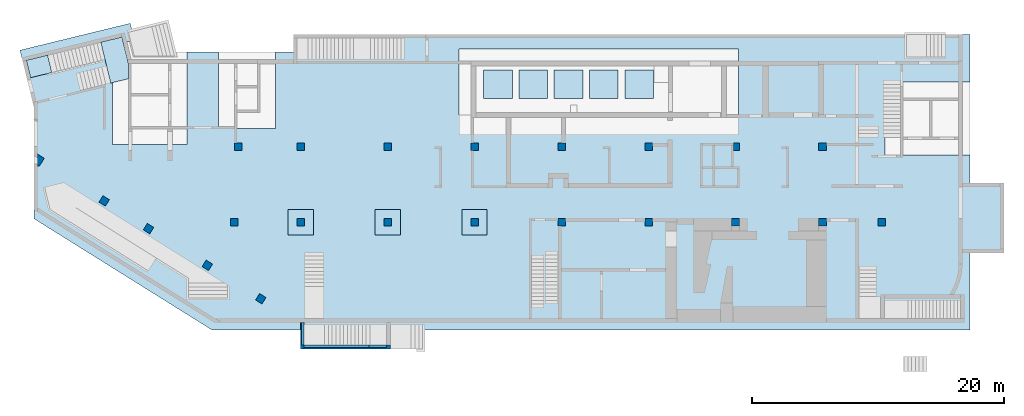
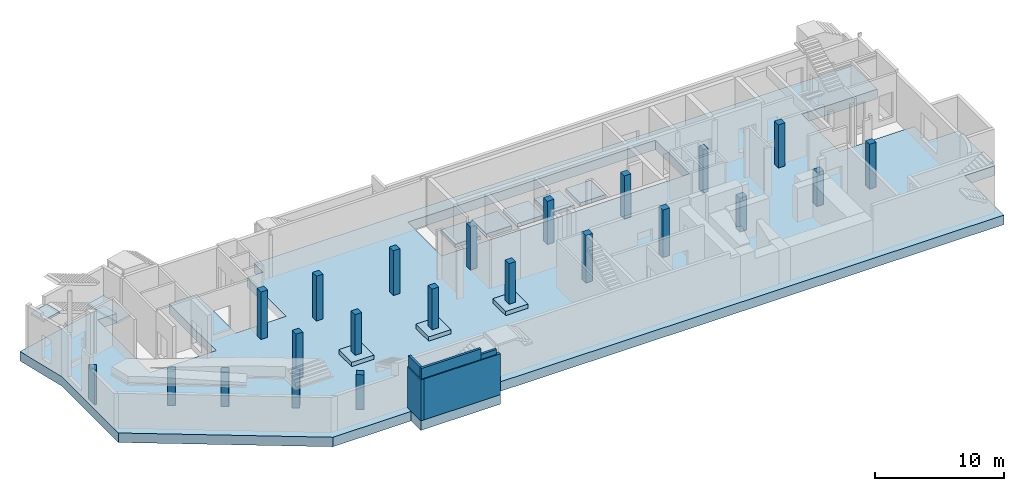
# One storey, part 1 of 9: 22 columns, 11 slabs, 5 walls.
"""IFC4 building model written with IfcOpenShell, lengths in millimetres."""

from ifc_helpers import new_model, entity, si_unit, converted_unit, derived_unit, direction, frame, origin, place, context, subcontext, project, spatial, indexed_curve, outline, extrude, source, transform, mapped, material, constituent, constituent_set, type_object, type_shapes, element, save


model = new_model("IFC4")

# Units and contexts
model_context = context("Model", 3, precision=0.01, world=origin(), true_north=direction((6.12303176911189e-17, 1.0)))
plan_context = context("Plan", 3, precision=0.01, world=origin(), true_north=direction((6.12303176911189e-17, 1.0)))
body_context = subcontext(model_context, "Body", "Model", "MODEL_VIEW")
ifc_project = project(units=[si_unit("LENGTHUNIT", "METRE", prefix="MILLI"), si_unit("AREAUNIT", "SQUARE_METRE"), si_unit("VOLUMEUNIT", "CUBIC_METRE"), converted_unit("PLANEANGLEUNIT", "DEGREE", entity("IfcRatioMeasure", 0.0174532925199433), si_unit("PLANEANGLEUNIT", "RADIAN"), dimensions=[0, 0, 0, 0, 0, 0, 0]), si_unit("MASSUNIT", "GRAM", prefix="KILO"), derived_unit("MASSDENSITYUNIT", [(si_unit("MASSUNIT", "GRAM", prefix="KILO"), 1), (si_unit("LENGTHUNIT", "METRE"), -3)]), derived_unit("MOMENTOFINERTIAUNIT", [(si_unit("LENGTHUNIT", "METRE"), 4)]), si_unit("TIMEUNIT", "SECOND"), si_unit("FREQUENCYUNIT", "HERTZ"), si_unit("THERMODYNAMICTEMPERATUREUNIT", "DEGREE_CELSIUS"), derived_unit("THERMALTRANSMITTANCEUNIT", [(si_unit("MASSUNIT", "GRAM", prefix="KILO"), 1), (si_unit("THERMODYNAMICTEMPERATUREUNIT", "KELVIN"), -1), (si_unit("TIMEUNIT", "SECOND"), -3)]), derived_unit("VOLUMETRICFLOWRATEUNIT", [(si_unit("LENGTHUNIT", "METRE"), 3), (si_unit("TIMEUNIT", "SECOND"), -1)]), derived_unit("MASSFLOWRATEUNIT", [(si_unit("MASSUNIT", "GRAM", prefix="KILO"), 1), (si_unit("TIMEUNIT", "SECOND"), -1)]), derived_unit("ROTATIONALFREQUENCYUNIT", [(si_unit("TIMEUNIT", "SECOND"), -1)]), si_unit("ELECTRICCURRENTUNIT", "AMPERE"), si_unit("ELECTRICVOLTAGEUNIT", "VOLT"), si_unit("POWERUNIT", "WATT"), si_unit("FORCEUNIT", "NEWTON", prefix="KILO"), si_unit("ILLUMINANCEUNIT", "LUX"), si_unit("LUMINOUSFLUXUNIT", "LUMEN"), si_unit("LUMINOUSINTENSITYUNIT", "CANDELA"), derived_unit("USERDEFINED", [(si_unit("MASSUNIT", "GRAM", prefix="KILO"), -1), (si_unit("LENGTHUNIT", "METRE"), -2), (si_unit("TIMEUNIT", "SECOND"), 3), (si_unit("LUMINOUSFLUXUNIT", "LUMEN"), 1)]), derived_unit("LINEARVELOCITYUNIT", [(si_unit("LENGTHUNIT", "METRE"), 1), (si_unit("TIMEUNIT", "SECOND"), -1)]), si_unit("PRESSUREUNIT", "PASCAL"), derived_unit("USERDEFINED", [(si_unit("LENGTHUNIT", "METRE"), -2), (si_unit("MASSUNIT", "GRAM", prefix="KILO"), 1), (si_unit("TIMEUNIT", "SECOND"), -2)]), derived_unit("LINEARFORCEUNIT", [(si_unit("MASSUNIT", "GRAM", prefix="KILO"), 1), (si_unit("LENGTHUNIT", "METRE"), 1), (si_unit("TIMEUNIT", "SECOND"), -2), (si_unit("LENGTHUNIT", "METRE"), -1)]), derived_unit("PLANARFORCEUNIT", [(si_unit("MASSUNIT", "GRAM", prefix="KILO"), 1), (si_unit("LENGTHUNIT", "METRE"), 1), (si_unit("TIMEUNIT", "SECOND"), -2), (si_unit("LENGTHUNIT", "METRE"), -2)])], contexts=[model_context, plan_context])

# Site, building, storey
site_placement = place(None, origin())
site = spatial("IfcSite", under=ifc_project, at=site_placement, CompositionType="ELEMENT")
building_placement = place(site_placement, origin())
building = spatial("IfcBuilding", under=site, at=building_placement, CompositionType="ELEMENT")
storey_placement = place(building_placement, frame((0.0, 0.0, -4900.0)))
storey = spatial("IfcBuildingStorey", under=building, at=storey_placement, CompositionType="ELEMENT", Elevation=-4900.0)

# Columns
ifc_material_1 = material()
column_type_1 = type_object("IfcColumnType", PredefinedType="COLUMN", material=ifc_material_1)
shared_shape_1 = source(origin(), body_context, "Body", "SweptSolid", [
    extrude(outline(indexed_curve([(-300.0, -300.000000000001), (300.0, -300.000000000001), (300.0, 299.999999999999), (-300.0, 299.999999999999), (-300.0, -300.000000000001)], self_intersect=False)), frame((15900.0, 7700.0, -4900.0), z_axis=(0.0, 0.0, 1.0), x_axis=(0.0, -1.0, 0.0)), (0.0, 0.0, 1.0), 4250.0),
])
type_shapes(column_type_1, [shared_shape_1])
placement_1 = place(storey_placement, frame((0.0, 0.0, 4900.0)))
element("IfcColumn", 1, at=placement_1, inside=storey, type_object=column_type_1, PredefinedType="COLUMN", context=body_context, shape_type="MappedRepresentation", body=[
    mapped(shared_shape_1, transform((0.0, 0.0, 0.0), scale=1.0)),
])
column_type_2 = type_object("IfcColumnType", PredefinedType="COLUMN", material=ifc_material_1)
shared_shape_2 = source(origin(), body_context, "Body", "SweptSolid", [
    extrude(outline(indexed_curve([(-300.000000000001, -300.000000000001), (299.999999999999, -300.000000000001), (299.999999999999, 299.999999999999), (-300.000000000001, 299.999999999999), (-300.000000000001, -300.000000000001)], self_intersect=False)), frame((16200.0, 13700.0, -4900.0), z_axis=(0.0, 0.0, 1.0), x_axis=(0.0, -1.0, 0.0)), (0.0, 0.0, 1.0), 4500.0),
])
type_shapes(column_type_2, [shared_shape_2])
element("IfcColumn", 2, at=placement_1, inside=storey, type_object=column_type_2, PredefinedType="COLUMN", context=body_context, shape_type="MappedRepresentation", body=[
    mapped(shared_shape_2, transform((0.0, 0.0, 0.0), scale=1.0)),
])
column_type_3 = type_object("IfcColumnType", PredefinedType="COLUMN", material=ifc_material_1)
shared_shape_3 = source(origin(), body_context, "Body", "SweptSolid", [
    extrude(outline(indexed_curve([(-299.999999999999, -300.000000000001), (300.000000000001, -300.000000000001), (299.999999999999, 299.999999999997), (-300.000000000001, 300.000000000001), (-299.999999999999, -300.000000000001)], self_intersect=False)), frame((21170.0, 13700.0, -4900.0), z_axis=(0.0, 0.0, 1.0), x_axis=(0.0, -1.0, 0.0)), (0.0, 0.0, 1.0), 4250.0),
])
type_shapes(column_type_3, [shared_shape_3])
element("IfcColumn", 3, at=placement_1, inside=storey, type_object=column_type_3, PredefinedType="COLUMN", context=body_context, shape_type="MappedRepresentation", body=[
    mapped(shared_shape_3, transform((0.0, 0.0, 0.0), scale=1.0)),
])
column_type_4 = type_object("IfcColumnType", PredefinedType="COLUMN", material=ifc_material_1)
shared_shape_4 = source(origin(), body_context, "Body", "SweptSolid", [
    extrude(outline(indexed_curve([(-299.999999999997, -300.000000000001), (300.000000000003, -300.000000000001), (300.000000000001, 299.999999999997), (-299.999999999999, 300.000000000001), (-299.999999999997, -300.000000000001)], self_intersect=False)), frame((28070.0, 13700.0, -4900.0), z_axis=(0.0, 0.0, 1.0), x_axis=(0.0, -1.0, 0.0)), (0.0, 0.0, 1.0), 4250.0),
])
type_shapes(column_type_4, [shared_shape_4])
element("IfcColumn", 4, at=placement_1, inside=storey, type_object=column_type_4, PredefinedType="COLUMN", context=body_context, shape_type="MappedRepresentation", body=[
    mapped(shared_shape_4, transform((0.0, 0.0, 0.0), scale=1.0)),
])
column_type_5 = type_object("IfcColumnType", PredefinedType="COLUMN", material=ifc_material_1)
shared_shape_5 = source(origin(), body_context, "Body", "SweptSolid", [
    extrude(outline(indexed_curve([(-299.999999999999, -300.000000000001), (300.000000000001, -300.000000000001), (299.999999999999, 299.999999999997), (-300.000000000001, 300.000000000001), (-299.999999999999, -300.000000000001)], self_intersect=False)), frame((34970.0, 13700.0, -4900.0), z_axis=(0.0, 0.0, 1.0), x_axis=(0.0, -1.0, 0.0)), (0.0, 0.0, 1.0), 4100.0),
])
type_shapes(column_type_5, [shared_shape_5])
element("IfcColumn", 5, at=placement_1, inside=storey, type_object=column_type_5, PredefinedType="COLUMN", context=body_context, shape_type="MappedRepresentation", body=[
    mapped(shared_shape_5, transform((0.0, 0.0, 0.0), scale=1.0)),
])
column_type_6 = type_object("IfcColumnType", PredefinedType="COLUMN", material=ifc_material_1)
shared_shape_6 = source(origin(), body_context, "Body", "SweptSolid", [
    extrude(outline(indexed_curve([(-300.000000000001, -300.000000000001), (299.999999999999, -300.000000000001), (299.999999999997, 300.000000000001), (-300.000000000003, 300.000000000001), (-300.000000000001, -300.000000000001)], self_intersect=False)), frame((41870.0, 13700.0, -4900.0), z_axis=(0.0, 0.0, 1.0), x_axis=(0.0, -1.0, 0.0)), (0.0, 0.0, 1.0), 4100.0),
])
type_shapes(column_type_6, [shared_shape_6])
element("IfcColumn", 6, at=placement_1, inside=storey, type_object=column_type_6, PredefinedType="COLUMN", context=body_context, shape_type="MappedRepresentation", body=[
    mapped(shared_shape_6, transform((0.0, 0.0, 0.0), scale=1.0)),
])
column_type_7 = type_object("IfcColumnType", PredefinedType="COLUMN", material=ifc_material_1)
shared_shape_7 = source(origin(), body_context, "Body", "SweptSolid", [
    extrude(outline(indexed_curve([(-299.999999999999, -300.000000000001), (300.000000000001, -300.000000000001), (299.999999999999, 300.000000000001), (-300.000000000001, 300.000000000001), (-299.999999999999, -300.000000000001)], self_intersect=False)), frame((48770.0, 13700.0, -4900.0), z_axis=(0.0, 0.0, 1.0), x_axis=(0.0, -1.0, 0.0)), (0.0, 0.0, 1.0), 4100.0),
])
type_shapes(column_type_7, [shared_shape_7])
element("IfcColumn", 7, at=placement_1, inside=storey, type_object=column_type_7, PredefinedType="COLUMN", context=body_context, shape_type="MappedRepresentation", body=[
    mapped(shared_shape_7, transform((0.0, 0.0, 0.0), scale=1.0)),
])
column_type_8 = type_object("IfcColumnType", PredefinedType="COLUMN", material=ifc_material_1)
shared_shape_8 = source(origin(), body_context, "Body", "SweptSolid", [
    extrude(outline(indexed_curve([(-299.999999999997, -225.000000000001), (300.000000000003, -225.000000000001), (300.000000000001, 225.000000000018), (-299.999999999999, 225.000000000018), (-299.999999999997, -225.000000000001)], self_intersect=False)), frame((55745.0, 13700.0, -4900.0), z_axis=(0.0, 0.0, 1.0), x_axis=(0.0, -1.0, 0.0)), (0.0, 0.0, 1.0), 4100.0),
])
type_shapes(column_type_8, [shared_shape_8])
element("IfcColumn", 8, at=placement_1, inside=storey, type_object=column_type_8, PredefinedType="COLUMN", context=body_context, shape_type="MappedRepresentation", body=[
    mapped(shared_shape_8, transform((0.0, 0.0, 0.0), scale=1.0)),
])
column_type_9 = type_object("IfcColumnType", PredefinedType="COLUMN", material=ifc_material_1)
shared_shape_9 = source(origin(), body_context, "Body", "SweptSolid", [
    extrude(outline(indexed_curve([(-299.999999999999, -300.000000000001), (300.000000000001, -300.000000000001), (299.999999999999, 300.000000000001), (-300.000000000001, 300.000000000001), (-299.999999999999, -300.000000000001)], self_intersect=False)), frame((62570.0, 13700.0, -4900.0), z_axis=(0.0, 0.0, 1.0), x_axis=(0.0, -1.0, 0.0)), (0.0, 0.0, 1.0), 4100.0),
])
type_shapes(column_type_9, [shared_shape_9])
element("IfcColumn", 9, at=placement_1, inside=storey, type_object=column_type_9, PredefinedType="COLUMN", context=body_context, shape_type="MappedRepresentation", body=[
    mapped(shared_shape_9, transform((0.0, 0.0, 0.0), scale=1.0)),
])
column_type_10 = type_object("IfcColumnType", PredefinedType="COLUMN", material=ifc_material_1)
shared_shape_10 = source(origin(), body_context, "Body", "SweptSolid", [
    extrude(outline(indexed_curve([(-300.0, -300.000000000001), (300.0, -300.000000000001), (300.0, 300.000000000001), (-300.0, 300.000000000001), (-300.0, -300.000000000001)], self_intersect=False)), frame((41870.0, 7700.0, -4900.0), z_axis=(0.0, 0.0, 1.0), x_axis=(0.0, -1.0, 0.0)), (0.0, 0.0, 1.0), 4500.0),
])
type_shapes(column_type_10, [shared_shape_10])
element("IfcColumn", 10, at=placement_1, inside=storey, type_object=column_type_10, PredefinedType="COLUMN", context=body_context, shape_type="MappedRepresentation", body=[
    mapped(shared_shape_10, transform((0.0, 0.0, 0.0), scale=1.0)),
])
column_type_11 = type_object("IfcColumnType", PredefinedType="COLUMN", material=ifc_material_1)
shared_shape_11 = source(origin(), body_context, "Body", "SweptSolid", [
    extrude(outline(indexed_curve([(-300.0, -300.000000000001), (300.0, -300.000000000001), (300.0, 300.000000000001), (-300.0, 300.000000000001), (-300.0, -300.000000000001)], self_intersect=False)), frame((48770.0, 7700.0, -4900.0), z_axis=(0.0, 0.0, 1.0), x_axis=(0.0, -1.0, 0.0)), (0.0, 0.0, 1.0), 4500.0),
])
type_shapes(column_type_11, [shared_shape_11])
element("IfcColumn", 11, at=placement_1, inside=storey, type_object=column_type_11, PredefinedType="COLUMN", context=body_context, shape_type="MappedRepresentation", body=[
    mapped(shared_shape_11, transform((0.0, 0.0, 0.0), scale=1.0)),
])
column_type_12 = type_object("IfcColumnType", PredefinedType="COLUMN", material=ifc_material_1)
shared_shape_12 = source(origin(), body_context, "Body", "SweptSolid", [
    extrude(outline(indexed_curve([(-300.0, -300.000000000001), (300.0, -300.000000000001), (300.0, 300.000000000001), (-300.0, 300.000000000001), (-300.0, -300.000000000001)], self_intersect=False)), frame((55670.0, 7700.0, -4900.0), z_axis=(0.0, 0.0, 1.0), x_axis=(0.0, -1.0, 0.0)), (0.0, 0.0, 1.0), 3200.0),
])
type_shapes(column_type_12, [shared_shape_12])
element("IfcColumn", 12, at=placement_1, inside=storey, type_object=column_type_12, PredefinedType="COLUMN", context=body_context, shape_type="MappedRepresentation", body=[
    mapped(shared_shape_12, transform((0.0, 0.0, 0.0), scale=1.0)),
])
column_type_13 = type_object("IfcColumnType", PredefinedType="COLUMN", material=ifc_material_1)
shared_shape_13 = source(origin(), body_context, "Body", "SweptSolid", [
    extrude(outline(indexed_curve([(-300.0, -300.000000000001), (300.0, -300.000000000001), (300.0, 300.000000000001), (-300.0, 300.000000000001), (-300.0, -300.000000000001)], self_intersect=False)), frame((62570.0, 7700.0, -4900.0), z_axis=(0.0, 0.0, 1.0), x_axis=(0.0, -1.0, 0.0)), (0.0, 0.0, 1.0), 3200.0),
])
type_shapes(column_type_13, [shared_shape_13])
element("IfcColumn", 13, at=placement_1, inside=storey, type_object=column_type_13, PredefinedType="COLUMN", context=body_context, shape_type="MappedRepresentation", body=[
    mapped(shared_shape_13, transform((0.0, 0.0, 0.0), scale=1.0)),
])
column_type_14 = type_object("IfcColumnType", PredefinedType="COLUMN", material=ifc_material_1)
shared_shape_14 = source(origin(), body_context, "Body", "SweptSolid", [
    extrude(outline(indexed_curve([(-300.0, -300.000000000001), (300.0, -300.000000000001), (300.0, 299.999999999997), (-300.0, 300.000000000001), (-300.0, -300.000000000001)], self_intersect=False)), frame((21170.0, 7700.0, -4500.0), z_axis=(0.0, 0.0, 1.0), x_axis=(0.0, -1.0, 0.0)), (0.0, 0.0, 1.0), 3850.0),
])
type_shapes(column_type_14, [shared_shape_14])
element("IfcColumn", 14, at=placement_1, inside=storey, type_object=column_type_14, PredefinedType="COLUMN", context=body_context, shape_type="MappedRepresentation", body=[
    mapped(shared_shape_14, transform((0.0, 0.0, 0.0), scale=1.0)),
])
column_type_15 = type_object("IfcColumnType", PredefinedType="COLUMN", material=ifc_material_1)
shared_shape_15 = source(origin(), body_context, "Body", "SweptSolid", [
    extrude(outline(indexed_curve([(-300.0, -300.000000000001), (300.0, -300.000000000001), (300.0, 299.999999999997), (-300.0, 300.000000000001), (-300.0, -300.000000000001)], self_intersect=False)), frame((28070.0, 7700.0, -4500.0), z_axis=(0.0, 0.0, 1.0), x_axis=(0.0, -1.0, 0.0)), (0.0, 0.0, 1.0), 3850.0),
])
type_shapes(column_type_15, [shared_shape_15])
element("IfcColumn", 15, at=placement_1, inside=storey, type_object=column_type_15, PredefinedType="COLUMN", context=body_context, shape_type="MappedRepresentation", body=[
    mapped(shared_shape_15, transform((0.0, 0.0, 0.0), scale=1.0)),
])
column_type_16 = type_object("IfcColumnType", PredefinedType="COLUMN", material=ifc_material_1)
shared_shape_16 = source(origin(), body_context, "Body", "SweptSolid", [
    extrude(outline(indexed_curve([(-300.0, -300.000000000001), (300.0, -300.000000000001), (300.0, 299.999999999997), (-300.0, 300.000000000001), (-300.0, -300.000000000001)], self_intersect=False)), frame((34970.0, 7700.0, -4500.0), z_axis=(0.0, 0.0, 1.0), x_axis=(0.0, -1.0, 0.0)), (0.0, 0.0, 1.0), 3850.0),
])
type_shapes(column_type_16, [shared_shape_16])
element("IfcColumn", 16, at=placement_1, inside=storey, type_object=column_type_16, PredefinedType="COLUMN", context=body_context, shape_type="MappedRepresentation", body=[
    mapped(shared_shape_16, transform((0.0, 0.0, 0.0), scale=1.0)),
])
column_type_17 = type_object("IfcColumnType", PredefinedType="COLUMN", material=ifc_material_1)
shared_shape_17 = source(origin(), body_context, "Body", "SweptSolid", [
    extrude(outline(indexed_curve([(-300.0, -300.0), (300.0, -300.0), (300.0, 300.0), (-300.0, 300.0), (-300.0, -300.0)], self_intersect=False)), frame((18003.04, 1625.89, -4900.0), z_axis=(0.0, 0.0, 1.0), x_axis=(-0.848052743777573, 0.529911826412028, 0.0)), (0.0, 0.0, 1.0), 3280.0),
])
type_shapes(column_type_17, [shared_shape_17])
element("IfcColumn", 17, at=placement_1, inside=storey, type_object=column_type_17, PredefinedType="COLUMN", context=body_context, shape_type="MappedRepresentation", body=[
    mapped(shared_shape_17, transform((0.0, 0.0, 0.0), scale=1.0)),
])
column_type_18 = type_object("IfcColumnType", PredefinedType="COLUMN", material=ifc_material_1)
shared_shape_18 = source(origin(), body_context, "Body", "SweptSolid", [
    extrude(outline(indexed_curve([(-300.0, -300.0), (300.0, -300.0), (300.0, 300.0), (-300.0, 300.0), (-300.0, -300.0)], self_intersect=False)), frame((13762.77, 4275.45, -4900.0), z_axis=(0.0, 0.0, 1.0), x_axis=(-0.848052743777572, 0.529911826412028, 0.0)), (0.0, 0.0, 1.0), 3280.0),
])
type_shapes(column_type_18, [shared_shape_18])
element("IfcColumn", 18, at=placement_1, inside=storey, type_object=column_type_18, PredefinedType="COLUMN", context=body_context, shape_type="MappedRepresentation", body=[
    mapped(shared_shape_18, transform((0.0, 0.0, 0.0), scale=1.0)),
])
column_type_19 = type_object("IfcColumnType", PredefinedType="COLUMN", material=ifc_material_1)
shared_shape_19 = source(origin(), body_context, "Body", "SweptSolid", [
    extrude(outline(indexed_curve([(-300.0, -300.0), (300.0, -300.0), (300.0, 300.0), (-300.0, 300.0), (-300.0, -300.0)], self_intersect=False)), frame((9098.48, 7189.96, -4900.0), z_axis=(0.0, 0.0, 1.0), x_axis=(-0.848052743777572, 0.529911826412028, 0.0)), (0.0, 0.0, 1.0), 3280.0),
])
type_shapes(column_type_19, [shared_shape_19])
element("IfcColumn", 19, at=placement_1, inside=storey, type_object=column_type_19, PredefinedType="COLUMN", context=body_context, shape_type="MappedRepresentation", body=[
    mapped(shared_shape_19, transform((0.0, 0.0, 0.0), scale=1.0)),
])
column_type_20 = type_object("IfcColumnType", PredefinedType="COLUMN", material=ifc_material_1)
shared_shape_20 = source(origin(), body_context, "Body", "SweptSolid", [
    extrude(outline(indexed_curve([(-300.0, -300.0), (300.0, -300.0), (300.0, 300.0), (-300.0, 300.0), (-300.0, -300.0)], self_intersect=False)), frame((5579.07, 9389.1, -4900.0), z_axis=(0.0, 0.0, 1.0), x_axis=(-0.848052743777572, 0.529911826412028, 0.0)), (0.0, 0.0, 1.0), 3280.0),
])
type_shapes(column_type_20, [shared_shape_20])
element("IfcColumn", 20, at=placement_1, inside=storey, type_object=column_type_20, PredefinedType="COLUMN", context=body_context, shape_type="MappedRepresentation", body=[
    mapped(shared_shape_20, transform((0.0, 0.0, 0.0), scale=1.0)),
])
column_type_21 = type_object("IfcColumnType", PredefinedType="COLUMN", material=ifc_material_1)
shared_shape_21 = source(origin(), body_context, "Body", "SweptSolid", [
    extrude(outline(indexed_curve([(-300.0, -300.000000000001), (300.0, -300.000000000001), (300.0, 300.000000000001), (-300.0, 300.000000000001), (-300.0, -300.000000000001)], self_intersect=False)), frame((67270.0, 7700.0, -4900.0), z_axis=(0.0, 0.0, 1.0), x_axis=(0.0, -1.0, 0.0)), (0.0, 0.0, 1.0), 4250.0),
])
type_shapes(column_type_21, [shared_shape_21])
element("IfcColumn", 21, at=placement_1, inside=storey, type_object=column_type_21, PredefinedType="COLUMN", context=body_context, shape_type="MappedRepresentation", body=[
    mapped(shared_shape_21, transform((0.0, 0.0, 0.0), scale=1.0)),
])
ifc_material_2 = material()
ifc_constituent_1 = constituent(ifc_material_2)
ifc_material_3 = material()
ifc_constituent_2 = constituent(ifc_material_3)
ifc_constituent_set = constituent_set(constituents=[ifc_constituent_1, ifc_constituent_2])
column_type_22 = type_object("IfcColumnType", PredefinedType="COLUMN", material=ifc_constituent_set)
shared_shape_22 = source(origin(), body_context, "Body", "SweptSolid", [
    extrude(outline(indexed_curve([(-543.222538329964, -170.163318495476), (378.949872142256, -170.163318495476), (378.949872142255, -15.3027456556089), (-214.677205954544, 355.62938264656), (-543.222538329964, -170.163318495476)], self_intersect=False)), frame((470.16, 12557.55, -4900.0), z_axis=(0.0, 0.0, 1.0), x_axis=(0.0, -1.0, 0.0)), (0.0, 0.0, 1.0), 3280.0),
])
type_shapes(column_type_22, [shared_shape_22])
element("IfcColumn", 22, at=placement_1, inside=storey, type_object=column_type_22, PredefinedType="COLUMN", context=body_context, shape_type="MappedRepresentation", body=[
    mapped(shared_shape_22, transform((0.0, 0.0, 0.0), scale=1.0)),
])

# Slabs
slab_type_1 = type_object("IfcSlabType", Name="900", PredefinedType="BASESLAB", material=ifc_material_1)
placement_2 = place(storey_placement, origin())
element("IfcSlab", 23, at=placement_2, inside=storey, type_object=slab_type_1, material=ifc_material_1, Name="900", ObjectType="900", PredefinedType="BASESLAB", context=body_context, shape_type="SweptSolid", body=[
    extrude(outline(indexed_curve([(40677.8945979547, -7707.60946829249), (43377.8945979547, -7707.60946829249), (43377.8945979547, -2182.60946829252), (40677.8945979547, -2182.60946829252), (40677.8945979547, 37.3905317075305), (33927.8945979547, 37.3905317075305), (33927.8945979547, 5837.39053170749), (40677.8945979547, 5837.39053170749), (40677.8945979547, 9617.3905317075), (-13002.1054020453, 9617.3905317075), (-13002.1054020453, 8217.39053170733), (-14417.1054020453, 8217.39053170733), (-14417.1054020453, 2167.3905317073), (-18942.1054020453, 2167.3905317073), (-18942.1054020453, 8217.39053170732), (-21442.1054020453, 8217.39053170732), (-21442.1054020453, 867.390531707281), (-27342.1054020453, 867.390531707254), (-27342.1054020453, 9067.39053170725), (-25598.7931104971, 9067.39053170726), (-25947.2001078711, 10496.6905344877), (-34691.1609264089, 8365.25757568542), (-33592.1054020453, 3856.50753372621), (-33592.1054020453, -5000.60946829221), (-19458.1054020453, -13832.6094682925), (-12452.1054020453, -13832.6094682925), (-12452.1054020453, -15332.6094682925), (-5302.10540204527, -15332.6094682925), (-5302.10540204527, -13832.6094682925), (40677.8945979547, -13832.6094682925), (40677.8945979547, -7707.60946829249)], self_intersect=False), holes=[indexed_curve([(22327.8945979547, 8467.39053170756), (22327.8945979547, 3217.39053170756), (127.894597954704, 3217.39053170745), (127.89459795467, 8467.39053170745), (22327.8945979547, 8467.39053170756)], self_intersect=False)]), frame((33592.11, 12982.61, -900.0)), (0.0, 0.0, 1.0), 900.0),
])
slab_type_2 = type_object("IfcSlabType", Name="350", PredefinedType="BASESLAB", material=ifc_material_1)
element("IfcSlab", 24, at=placement_2, inside=storey, type_object=slab_type_2, material=ifc_material_1, Name="350", ObjectType="350", PredefinedType="BASESLAB", context=body_context, shape_type="SweptSolid", body=[
    extrude(outline(indexed_curve([(-1140.0, -1140.0), (1140.00000000001, -1140.0), (1140.0, 1140.00000000001), (-1140.00000000001, 1140.0), (-1140.0, -1140.0)], self_intersect=False)), frame((36825.0, 18650.0, -400.0), z_axis=(0.0, 0.0, -1.0), x_axis=(0.0, 1.0, 0.0)), (0.0, 0.0, 1.0), 349.999999999999),
])
slab_type_3 = type_object("IfcSlabType", Name="350", PredefinedType="BASESLAB", material=ifc_material_1)
element("IfcSlab", 25, at=placement_2, inside=storey, type_object=slab_type_3, material=ifc_material_1, Name="350", ObjectType="350", PredefinedType="BASESLAB", context=body_context, shape_type="SweptSolid", body=[
    extrude(outline(indexed_curve([(-1140.0, -1140.0), (1140.00000000001, -1140.0), (1140.0, 1140.00000000001), (-1140.00000000001, 1140.0), (-1140.0, -1140.0)], self_intersect=False)), frame((39625.0, 18650.0, -400.0), z_axis=(0.0, 0.0, -1.0), x_axis=(0.0, 1.0, 0.0)), (0.0, 0.0, 1.0), 349.999999999999),
])
slab_type_4 = type_object("IfcSlabType", Name="350", PredefinedType="BASESLAB", material=ifc_material_1)
element("IfcSlab", 26, at=placement_2, inside=storey, type_object=slab_type_4, material=ifc_material_1, Name="350", ObjectType="350", PredefinedType="BASESLAB", context=body_context, shape_type="SweptSolid", body=[
    extrude(outline(indexed_curve([(-1140.0, -1140.0), (1140.00000000001, -1140.0), (1140.0, 1140.00000000001), (-1140.00000000001, 1140.0), (-1140.0, -1140.0)], self_intersect=False)), frame((42425.0, 18650.0, -400.0), z_axis=(0.0, 0.0, -1.0), x_axis=(0.0, 1.0, 0.0)), (0.0, 0.0, 1.0), 349.999999999999),
])
slab_type_5 = type_object("IfcSlabType", Name="350", PredefinedType="BASESLAB", material=ifc_material_1)
element("IfcSlab", 27, at=placement_2, inside=storey, type_object=slab_type_5, material=ifc_material_1, Name="350", ObjectType="350", PredefinedType="BASESLAB", context=body_context, shape_type="SweptSolid", body=[
    extrude(outline(indexed_curve([(-1140.0, -1140.0), (1140.00000000001, -1140.0), (1140.0, 1140.00000000001), (-1140.00000000001, 1140.0), (-1140.0, -1140.0)], self_intersect=False)), frame((45225.0, 18650.0, -400.0), z_axis=(0.0, 0.0, -1.0), x_axis=(0.0, 1.0, 0.0)), (0.0, 0.0, 1.0), 349.999999999999),
])
slab_type_6 = type_object("IfcSlabType", Name="350", PredefinedType="BASESLAB", material=ifc_material_1)
element("IfcSlab", 28, at=placement_2, inside=storey, type_object=slab_type_6, material=ifc_material_1, Name="350", ObjectType="350", PredefinedType="BASESLAB", context=body_context, shape_type="SweptSolid", body=[
    extrude(outline(indexed_curve([(-1140.0, -1140.0), (1140.00000000001, -1140.0), (1140.0, 1140.00000000001), (-1140.00000000001, 1140.0), (-1140.0, -1140.0)], self_intersect=False)), frame((48025.0, 18650.0, -400.0), z_axis=(0.0, 0.0, -1.0), x_axis=(0.0, 1.0, 0.0)), (0.0, 0.0, 1.0), 349.999999999999),
])
slab_type_7 = type_object("IfcSlabType", Name="400", PredefinedType="BASESLAB", material=ifc_material_1)
element("IfcSlab", 29, at=placement_2, inside=storey, type_object=slab_type_7, material=ifc_material_1, Name="400", ObjectType="400", PredefinedType="BASESLAB", context=body_context, shape_type="SweptSolid", body=[
    extrude(outline(indexed_curve([(-1000.0, -1000.0), (1000.0, -1000.0), (1000.0, 999.999999999998), (-1000.0, 999.999999999998), (-1000.0, -1000.0)], self_intersect=False)), frame((21170.0, 7700.0, 400.0), z_axis=(0.0, 0.0, -1.0), x_axis=(0.0, 1.0, 0.0)), (0.0, 0.0, 1.0), 400.0),
])
slab_type_8 = type_object("IfcSlabType", Name="400", PredefinedType="BASESLAB", material=ifc_material_1)
element("IfcSlab", 30, at=placement_2, inside=storey, type_object=slab_type_8, material=ifc_material_1, Name="400", ObjectType="400", PredefinedType="BASESLAB", context=body_context, shape_type="SweptSolid", body=[
    extrude(outline(indexed_curve([(-1000.0, -999.999999999998), (1000.0, -999.999999999998), (1000.0, 1000.0), (-1000.0, 1000.0), (-1000.0, -999.999999999998)], self_intersect=False)), frame((28070.0, 7700.0, 400.0), z_axis=(0.0, 0.0, -1.0), x_axis=(0.0, 1.0, 0.0)), (0.0, 0.0, 1.0), 400.0),
])
slab_type_9 = type_object("IfcSlabType", Name="400", PredefinedType="BASESLAB", material=ifc_material_1)
element("IfcSlab", 31, at=placement_2, inside=storey, type_object=slab_type_9, material=ifc_material_1, Name="400", ObjectType="400", PredefinedType="BASESLAB", context=body_context, shape_type="SweptSolid", body=[
    extrude(outline(indexed_curve([(-1000.0, -999.999999999998), (1000.0, -999.999999999998), (1000.0, 1000.0), (-1000.0, 1000.0), (-1000.0, -999.999999999998)], self_intersect=False)), frame((34970.0, 7700.0, 400.0), z_axis=(0.0, 0.0, -1.0), x_axis=(0.0, 1.0, 0.0)), (0.0, 0.0, 1.0), 400.0),
])
slab_type_10 = type_object("IfcSlabType", Name=":ADSK_ 25_200", PredefinedType="FLOOR", material=ifc_material_1)
element("IfcSlab", 32, at=placement_2, inside=storey, type_object=slab_type_10, material=ifc_material_1, Name=":ADSK_ 25_200", ObjectType=":ADSK_ 25_200", PredefinedType="FLOOR", context=body_context, shape_type="SweptSolid", body=[
    extrude(outline(indexed_curve([(199.032465229822, -820.264699289819), (1419.20577821791, -820.264699289819), (1760.47954860354, 579.772052662983), (-1484.50432558899, 1370.7712032507), (-1894.21346646227, -310.013857334047), (199.032465229822, -820.264699289819)], self_intersect=False)), frame((6679.74, 20499.03, 1870.0), z_axis=(0.0, 0.0, -1.0), x_axis=(0.0, -1.0, 0.0)), (0.0, 0.0, 1.0), 200.0),
])
slab_type_11 = type_object("IfcSlabType", Name=":ADSK_ 25_200", PredefinedType="FLOOR", material=ifc_material_1)
element("IfcSlab", 33, at=placement_2, inside=storey, type_object=slab_type_11, material=ifc_material_1, Name=":ADSK_ 25_200", ObjectType=":ADSK_ 25_200", PredefinedType="FLOOR", context=body_context, shape_type="SweptSolid", body=[
    extrude(outline(indexed_curve([(-864.999999999999, -709.999999999996), (865.000000000001, -709.999999999996), (864.999999999999, 709.999999999996), (-865.000000000001, 709.999999999996), (-864.999999999999, -709.999999999996)], self_intersect=False)), frame((414.09, 20059.57, 3970.0), z_axis=(0.0, 0.0, -1.0), x_axis=(0.971552058141474, 0.236826092990334, 0.0)), (0.0, 0.0, 1.0), 200.0),
])

# Walls
wall_type_1 = type_object("IfcWallType", Name=":ADSK_ 25_200", PredefinedType="STANDARD")
wall_1_placement = place(storey_placement, frame((21240.0, -2150.0, 3870.0)))
element("IfcWall", 34, at=wall_1_placement, inside=storey, type_object=wall_type_1, material=ifc_material_1, Name=":ADSK_ 25_200", ObjectType=":ADSK_ 25_200", PredefinedType="NOTDEFINED", context=body_context, shape_type="SweptSolid", body=[
    extrude(outline(indexed_curve([(5350.0, 100.0), (-3.24069724826527e-13, 100.0), (3.24069724826527e-13, -100.0), (5350.0, -100.0), (5350.0, 100.0)], self_intersect=False)), origin(), (0.0, 0.0, 1.0), 999.999999999997),
])
wall_2_placement = place(storey_placement, frame((26590.0, -2150.0, 3870.0)))
element("IfcWall", 35, at=wall_2_placement, inside=storey, type_object=wall_type_1, material=ifc_material_1, Name=":ADSK_ 25_200", ObjectType=":ADSK_ 25_200", PredefinedType="NOTDEFINED", context=body_context, shape_type="SweptSolid", body=[
    extrude(outline(indexed_curve([(1400.0, 99.9999999999999), (-3.24069724826527e-13, 100.0), (3.24069724826527e-13, -100.0), (1400.0, -100.0), (1400.0, 99.9999999999999)], self_intersect=False)), origin(), (0.0, 0.0, 1.0), 455.0),
])
wall_3_placement = place(storey_placement, frame((21340.0, -192.08, 3870.0), z_axis=(0.0, 0.0, 1.0), x_axis=(0.0, -1.0, 0.0)))
element("IfcWall", 36, at=wall_3_placement, inside=storey, type_object=wall_type_1, material=ifc_material_1, Name=":ADSK_ 25_200", ObjectType=":ADSK_ 25_200", PredefinedType="NOTDEFINED", context=body_context, shape_type="SweptSolid", body=[
    extrude(outline(indexed_curve([(1857.91995714394, -100.000000000003), (1857.91995714394, 99.9999999999989), (57.9199571439329, 99.9999999999989), (57.9199571439315, -100.000000000003), (1857.91995714394, -100.000000000003)], self_intersect=False)), origin(), (0.0, 0.0, 1.0), 999.999999999997),
])
wall_type_2 = type_object("IfcWallType", Name=":ADSK_ 25_300", PredefinedType="STANDARD")
wall_4_placement = place(storey_placement, frame((21290.0, -2350.0, 0.0), z_axis=(0.0, 0.0, 1.0), x_axis=(0.0, 1.0, 0.0)))
element("IfcWall", 37, at=wall_4_placement, inside=storey, type_object=wall_type_2, material=ifc_material_1, Name=":ADSK_ 25_300", ObjectType=":ADSK_ 25_300", PredefinedType="NOTDEFINED", context=body_context, shape_type="SweptSolid", body=[
    extrude(outline(indexed_curve([(2100.00000000001, 150.000000000001), (0.0, 150.000000000001), (0.0, -150.000000000001), (2100.00000000001, -150.000000000001), (2100.00000000001, 150.000000000001)], self_intersect=False)), origin(), (0.0, 0.0, 1.0), 3870.0),
])
wall_5_placement = place(storey_placement, frame((21440.0, -2200.0, 0.0)))
element("IfcWall", 38, at=wall_5_placement, inside=storey, type_object=wall_type_2, material=ifc_material_1, Name=":ADSK_ 25_300", ObjectType=":ADSK_ 25_300", PredefinedType="NOTDEFINED", context=body_context, shape_type="SweptSolid", body=[
    extrude(outline(indexed_curve([(6849.99999999999, 150.0), (-4.88206460399072e-13, 150.0), (4.88206460399072e-13, -150.0), (6849.99999999999, -150.0), (6849.99999999999, 150.0)], self_intersect=False)), origin(), (0.0, 0.0, 1.0), 3870.0),
])

save(model, "model.ifc")
